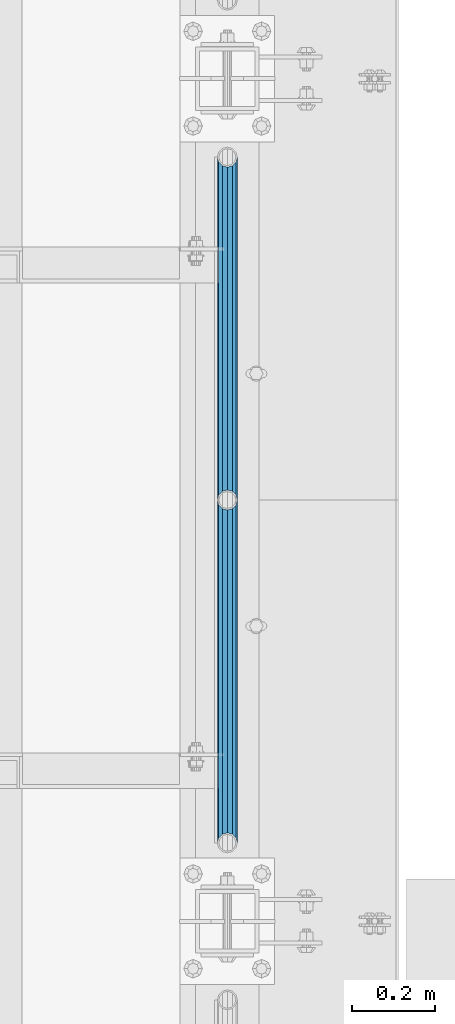
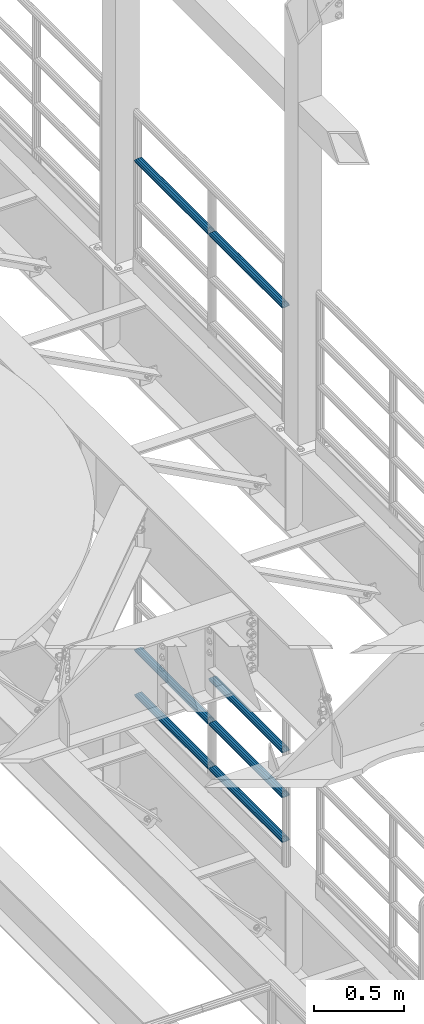
# One storey, part 1265 of 1876: 7 beams, 2 elements without a shape of their own.
"""IFC2X3 building model written with IfcOpenShell, lengths in millimetres."""

from ifc_helpers import new_model, si_unit, frame, origin_with_axes, place, context, subcontext, project, spatial, faceted_brep, material, type_object, element, aggregate, save


model = new_model("IFC2X3")

# Units and contexts
model_context = context("Model", 3, precision=1e-05, world=origin_with_axes())
body_context = subcontext(model_context, "Body", "Model", "MODEL_VIEW")
ifc_project = project(units=[si_unit("LENGTHUNIT", "METRE", prefix="MILLI"), si_unit("AREAUNIT", "SQUARE_METRE"), si_unit("VOLUMEUNIT", "CUBIC_METRE"), si_unit("MASSUNIT", "GRAM", prefix="KILO"), si_unit("TIMEUNIT", "SECOND"), si_unit("PLANEANGLEUNIT", "RADIAN"), si_unit("SOLIDANGLEUNIT", "STERADIAN"), si_unit("THERMODYNAMICTEMPERATUREUNIT", "DEGREE_CELSIUS"), si_unit("LUMINOUSINTENSITYUNIT", "LUMEN")], contexts=[model_context])

# Site, building, storey
site_placement = place(None, origin_with_axes())
site = spatial("IfcSite", under=ifc_project, at=site_placement, CompositionType="ELEMENT")
building_placement = place(site_placement, origin_with_axes())
building = spatial("IfcBuilding", under=site, at=building_placement, Name="Undefined", CompositionType="ELEMENT")
storey_placement = place(building_placement, origin_with_axes())
storey = spatial("IfcBuildingStorey", under=building, at=storey_placement, Name="Undefined", CompositionType="ELEMENT", Elevation=0.0)

# Assembly, beams
assembly_1_placement = place(storey_placement, origin_with_axes())
assembly_1 = element("IfcElementAssembly", 1, at=assembly_1_placement, inside=storey, Name="RAIL", AssemblyPlace="NOTDEFINED", PredefinedType="RIGID_FRAME")
ifc_material = material()
beam_type = type_object("IfcBeamType", Name="PIPE1-1/2SCH40", PredefinedType="NOTDEFINED")
beam_1_placement = place(assembly_1_placement, frame((7620.0, -2350.77, 8924.925), z_axis=(0.0, 0.0, -1.0), x_axis=(0.0, 1.0, 0.0)))
beam_1 = element("IfcBeam", 2, at=beam_1_placement, type_object=beam_type, material=ifc_material, Name="RAIL", ObjectType="PIPE1-1/2SCH40", context=body_context, shape_type="Brep", body=[
    faceted_brep([(0.0, 24.1299999999992, 0.0), (12.0650000000064, 20.8971929933177, -12.0649999999987), (12.0650000000064, 20.8971929933177, 12.0649999999987), (12.0650000000064, -20.8971929933177, 12.0649999999987), (12.0650000000064, -20.8971929933177, -12.0649999999987), (0.0, -24.1299999999992, 0.0), (20.8971929933249, -12.0650000000005, 20.8971929933177), (20.8971929933249, -12.0650000000005, 15.8661214311796), (15.2545715621445, -17.7076214311801, 10.2235000000001), (12.5151929933249, -20.4470000000001, 0.0), (15.2545715621445, -17.7076214311801, -10.2235000000001), (20.8971929933249, -12.0650000000005, -15.8661214311796), (20.8971929933249, -12.0650000000005, -20.8971929933177), (24.1300000000063, 0.0, -20.4470000000001), (24.1300000000063, 0.0, -24.130000000001), (21.3906214311868, -10.2235000000001, -17.7076214311819), (21.3906214311868, 10.2235000000001, -17.7076214311819), (20.8971929933249, 12.0650000000005, -15.8661214311796), (20.8971929933249, 12.0650000000005, -20.8971929933177), (15.2545715621445, 17.7076214311801, -10.2235000000001), (12.5151929933249, 20.4470000000001, 0.0), (15.2545715621445, 17.7076214311801, 10.2235000000001), (20.8971929933249, 12.0650000000005, 15.8661214311796), (20.8971929933249, 12.0650000000005, 20.8971929933177), (21.3906214311868, 10.2235000000001, 17.7076214311819), (24.1300000000064, 0.0, 20.4470000000001), (24.1300000000064, 0.0, 24.130000000001), (21.3906214311868, -10.2235000000001, 17.7076214311819), (826.77, 24.1300000000001, 0.0), (814.705, 20.8971929933186, -12.0649999999987), (805.872807006681, 12.0649999999996, -20.8971929933177), (826.77, -24.1300000000001, 0.0), (814.705, -20.8971929933186, -12.0649999999987), (814.705, -20.8971929933186, 12.0649999999987), (805.872807006681, -12.0649999999996, 20.8971929933177), (805.872807006681, -12.0649999999996, -20.8971929933177), (802.640000000001, 0.0, -24.130000000001), (805.379378568819, 10.2235000000001, -17.7076214311819), (802.640000000001, 0.0, -20.4470000000001), (805.872807006683, 12.0649999999996, -15.8661214311796), (805.872807006683, -12.0649999999996, -15.8661214311796), (805.379378568819, -10.2235000000001, -17.7076214311819), (811.515428437862, -17.7076214311801, -10.2235000000001), (814.254807006682, -20.4470000000001, 0.0), (811.515428437862, -17.7076214311801, 10.2235000000001), (805.872807006683, -12.0649999999996, 15.8661214311796), (805.379378568819, -10.2235000000001, 17.7076214311819), (802.640000000001, 0.0, 20.4470000000001), (802.640000000001, 0.0, 24.130000000001), (805.872807006681, 12.0649999999996, 20.8971929933177), (814.705, 20.8971929933186, 12.0649999999987), (805.872807006683, 12.0649999999996, 15.8661214311796), (811.515428437862, 17.7076214311801, 10.2235000000001), (814.254807006682, 20.4470000000001, 0.0), (811.515428437862, 17.7076214311801, -10.2235000000001), (805.379378568819, 10.2235000000001, 17.7076214311819)], [[[0, 1, 2]], [[3, 4, 5]], [[6, 7, 8, 9, 10, 11, 12, 4, 3]], [[13, 14, 12, 11, 15]], [[16, 17, 18, 14, 13]], [[2, 1, 18, 17, 19, 20, 21, 22, 23]], [[23, 22, 24, 25, 26]], [[26, 25, 27, 7, 6]], [[1, 0, 28, 29]], [[18, 1, 29, 30]], [[31, 32, 33]], [[6, 3, 33, 34]], [[3, 5, 31, 33]], [[5, 4, 32, 31]], [[4, 12, 35, 32]], [[12, 14, 36, 35]], [[14, 18, 30, 36]], [[37, 38, 36, 30, 39]], [[40, 35, 36, 38, 41]], [[33, 32, 35, 40, 42, 43, 44, 45, 34]], [[34, 45, 46, 47, 48]], [[26, 6, 34, 48]], [[2, 23, 49, 50]], [[23, 26, 48, 49]], [[0, 2, 50, 28]], [[28, 50, 29]], [[49, 51, 52, 53, 54, 39, 30, 29, 50]], [[48, 47, 55, 51, 49]], [[25, 24, 55, 47]], [[55, 24, 22, 21, 52, 51]], [[21, 20, 53, 52]], [[20, 19, 54, 53]], [[19, 17, 16, 37, 39, 54]], [[16, 13, 38, 37]], [[13, 15, 41, 38]], [[41, 15, 11, 10, 42, 40]], [[10, 9, 43, 42]], [[9, 8, 44, 43]], [[8, 7, 27, 46, 45, 44]], [[27, 25, 47, 46]]]),
])
beam_2_placement = place(assembly_1_placement, frame((7620.0, -1524.0, 8924.925), z_axis=(0.0, 0.0, -1.0), x_axis=(0.0, 1.0, 0.0)))
beam_2 = element("IfcBeam", 3, at=beam_2_placement, type_object=beam_type, material=ifc_material, Name="RAIL", ObjectType="PIPE1-1/2SCH40", context=body_context, shape_type="Brep", body=[
    faceted_brep([(0.0, 24.1299999999992, 0.0), (12.0650000000064, 20.8971929933177, -12.0649999999987), (12.0650000000064, 20.8971929933177, 12.0649999999987), (12.0650000000064, -20.8971929933177, 12.0649999999987), (12.0650000000064, -20.8971929933177, -12.0649999999987), (0.0, -24.1299999999992, 0.0), (20.8971929933249, -12.0650000000005, 20.8971929933177), (20.8971929933249, -12.0650000000005, 15.8661214311796), (15.2545715621445, -17.7076214311801, 10.2235000000001), (12.5151929933249, -20.4470000000001, 0.0), (15.2545715621445, -17.7076214311801, -10.2235000000001), (20.8971929933249, -12.0650000000005, -15.8661214311796), (20.8971929933249, -12.0650000000005, -20.8971929933177), (24.1300000000063, 0.0, -20.4470000000001), (24.1300000000063, 0.0, -24.130000000001), (21.3906214311868, -10.2235000000001, -17.7076214311819), (21.3906214311868, 10.2235000000001, -17.7076214311819), (20.8971929933249, 12.0650000000005, -15.8661214311796), (20.8971929933249, 12.0650000000005, -20.8971929933177), (15.2545715621445, 17.7076214311801, -10.2235000000001), (12.5151929933249, 20.4470000000001, 0.0), (15.2545715621445, 17.7076214311801, 10.2235000000001), (20.8971929933249, 12.0650000000005, 15.8661214311796), (20.8971929933249, 12.0650000000005, 20.8971929933177), (21.3906214311868, 10.2235000000001, 17.7076214311819), (24.1300000000064, 0.0, 20.4470000000001), (24.1300000000064, 0.0, 24.130000000001), (21.3906214311868, -10.2235000000001, 17.7076214311819), (826.77, 24.1300000000001, 0.0), (814.705, 20.8971929933186, -12.0649999999987), (805.872807006681, 12.0649999999996, -20.8971929933177), (826.77, -24.1300000000001, 0.0), (814.705, -20.8971929933186, -12.0649999999987), (814.705, -20.8971929933186, 12.0649999999987), (805.872807006681, -12.0649999999996, 20.8971929933177), (805.872807006681, -12.0649999999996, -20.8971929933177), (802.640000000001, 0.0, -24.130000000001), (805.379378568819, 10.2235000000001, -17.7076214311819), (802.640000000001, 0.0, -20.4470000000001), (805.872807006683, 12.0649999999996, -15.8661214311796), (805.872807006683, -12.0649999999996, -15.8661214311796), (805.379378568819, -10.2235000000001, -17.7076214311819), (811.515428437862, -17.7076214311801, -10.2235000000001), (814.254807006682, -20.4470000000001, 0.0), (811.515428437862, -17.7076214311801, 10.2235000000001), (805.872807006683, -12.0649999999996, 15.8661214311796), (805.379378568819, -10.2235000000001, 17.7076214311819), (802.640000000001, 0.0, 20.4470000000001), (802.640000000001, 0.0, 24.130000000001), (805.872807006681, 12.0649999999996, 20.8971929933177), (814.705, 20.8971929933186, 12.0649999999987), (805.872807006683, 12.0649999999996, 15.8661214311796), (811.515428437862, 17.7076214311801, 10.2235000000001), (814.254807006682, 20.4470000000001, 0.0), (811.515428437862, 17.7076214311801, -10.2235000000001), (805.379378568819, 10.2235000000001, 17.7076214311819)], [[[0, 1, 2]], [[3, 4, 5]], [[6, 7, 8, 9, 10, 11, 12, 4, 3]], [[13, 14, 12, 11, 15]], [[16, 17, 18, 14, 13]], [[2, 1, 18, 17, 19, 20, 21, 22, 23]], [[23, 22, 24, 25, 26]], [[26, 25, 27, 7, 6]], [[1, 0, 28, 29]], [[18, 1, 29, 30]], [[31, 32, 33]], [[6, 3, 33, 34]], [[3, 5, 31, 33]], [[5, 4, 32, 31]], [[4, 12, 35, 32]], [[12, 14, 36, 35]], [[14, 18, 30, 36]], [[37, 38, 36, 30, 39]], [[40, 35, 36, 38, 41]], [[33, 32, 35, 40, 42, 43, 44, 45, 34]], [[34, 45, 46, 47, 48]], [[26, 6, 34, 48]], [[2, 23, 49, 50]], [[23, 26, 48, 49]], [[0, 2, 50, 28]], [[28, 50, 29]], [[49, 51, 52, 53, 54, 39, 30, 29, 50]], [[48, 47, 55, 51, 49]], [[25, 24, 55, 47]], [[55, 24, 22, 21, 52, 51]], [[21, 20, 53, 52]], [[20, 19, 54, 53]], [[19, 17, 16, 37, 39, 54]], [[16, 13, 38, 37]], [[13, 15, 41, 38]], [[41, 15, 11, 10, 42, 40]], [[10, 9, 43, 42]], [[9, 8, 44, 43]], [[8, 7, 27, 46, 45, 44]], [[27, 25, 47, 46]]]),
])
aggregate(assembly_1, [beam_1, beam_2])

assembly_2_placement = place(storey_placement, origin_with_axes())
assembly_2 = element("IfcElementAssembly", 4, at=assembly_2_placement, inside=storey, Name="RAIL", AssemblyPlace="NOTDEFINED", PredefinedType="RIGID_FRAME")
beam_3_placement = place(assembly_2_placement, frame((7620.0, -1524.0, 5292.725), z_axis=(0.0, 0.0, 1.0), x_axis=(0.0, -1.0, 0.0)))
beam_3 = element("IfcBeam", 5, at=beam_3_placement, type_object=beam_type, material=ifc_material, Name="RAIL", ObjectType="PIPE1-1/2SCH40", context=body_context, shape_type="Brep", body=[
    faceted_brep([(805.872807006681, -12.0649999999996, 20.8971929933177), (805.872807006683, -12.0649999999996, 15.8661214311796), (805.379378568819, -10.2235000000001, 17.7076214311819), (802.640000000001, 0.0, 20.4470000000001), (802.640000000001, 0.0, 24.130000000001), (805.379378568819, 10.2235000000001, 17.7076214311819), (805.872807006683, 12.0649999999996, 15.8661214311796), (805.872807006681, 12.0649999999996, 20.8971929933177), (826.77, 24.1300000000001, 0.0), (814.705, 20.8971929933186, 12.0649999999987), (814.705, 20.8971929933186, -12.0649999999987), (811.515428437862, 17.7076214311801, 10.2235000000001), (814.254807006682, 20.4470000000001, 0.0), (811.515428437862, 17.7076214311801, -10.2235000000001), (805.872807006683, 12.0649999999996, -15.8661214311796), (805.872807006681, 12.0649999999996, -20.8971929933177), (805.379378568819, 10.2235000000001, -17.7076214311819), (802.640000000001, 0.0, -20.4470000000001), (802.640000000001, 0.0, -24.130000000001), (805.872807006683, -12.0649999999996, -15.8661214311796), (805.872807006681, -12.0649999999996, -20.8971929933177), (805.379378568819, -10.2235000000001, -17.7076214311819), (826.77, -24.1300000000001, 0.0), (814.705, -20.8971929933186, -12.0649999999987), (814.705, -20.8971929933186, 12.0649999999987), (811.515428437862, -17.7076214311801, -10.2235000000001), (814.254807006682, -20.4470000000001, 0.0), (811.515428437862, -17.7076214311801, 10.2235000000001), (12.0650000000064, -20.8971929933177, -12.0649999999987), (20.8971929933249, -12.0650000000005, -20.8971929933177), (0.0, 24.1299999999992, 0.0), (12.0650000000064, 20.8971929933177, -12.0649999999987), (12.0650000000064, 20.8971929933177, 12.0649999999987), (20.8971929933249, 12.0650000000005, 20.8971929933177), (24.1300000000064, 0.0, 24.130000000001), (20.8971929933249, 12.0650000000005, -20.8971929933177), (24.1300000000063, 0.0, -24.130000000001), (24.1300000000063, 0.0, -20.4470000000001), (20.8971929933249, -12.0650000000005, -15.8661214311796), (21.3906214311868, -10.2235000000001, -17.7076214311819), (21.3906214311868, 10.2235000000001, -17.7076214311819), (20.8971929933249, 12.0650000000005, -15.8661214311796), (15.2545715621445, 17.7076214311801, -10.2235000000001), (12.5151929933249, 20.4470000000001, 0.0), (15.2545715621445, 17.7076214311801, 10.2235000000001), (20.8971929933249, 12.0650000000005, 15.8661214311796), (21.3906214311868, 10.2235000000001, 17.7076214311819), (24.1300000000064, 0.0, 20.4470000000001), (21.3906214311868, -10.2235000000001, 17.7076214311819), (20.8971929933249, -12.0650000000005, 15.8661214311796), (20.8971929933249, -12.0650000000005, 20.8971929933177), (12.0650000000064, -20.8971929933177, 12.0649999999987), (0.0, -24.1299999999992, 0.0), (15.2545715621445, -17.7076214311801, 10.2235000000001), (12.5151929933249, -20.4470000000001, 0.0), (15.2545715621445, -17.7076214311801, -10.2235000000001)], [[[0, 1, 2, 3, 4]], [[4, 3, 5, 6, 7]], [[8, 9, 10]], [[7, 6, 11, 12, 13, 14, 15, 10, 9]], [[16, 17, 18, 15, 14]], [[19, 20, 18, 17, 21]], [[22, 23, 24]], [[24, 23, 20, 19, 25, 26, 27, 1, 0]], [[28, 29, 20, 23]], [[30, 31, 32]], [[33, 34, 4, 7]], [[32, 33, 7, 9]], [[30, 32, 9, 8]], [[31, 30, 8, 10]], [[35, 31, 10, 15]], [[36, 35, 15, 18]], [[29, 36, 18, 20]], [[37, 36, 29, 38, 39]], [[40, 41, 35, 36, 37]], [[32, 31, 35, 41, 42, 43, 44, 45, 33]], [[33, 45, 46, 47, 34]], [[34, 47, 48, 49, 50]], [[34, 50, 0, 4]], [[50, 51, 24, 0]], [[51, 52, 22, 24]], [[52, 28, 23, 22]], [[51, 28, 52]], [[50, 49, 53, 54, 55, 38, 29, 28, 51]], [[55, 54, 26, 25]], [[21, 39, 38, 55, 25, 19]], [[37, 39, 21, 17]], [[40, 37, 17, 16]], [[42, 41, 40, 16, 14, 13]], [[43, 42, 13, 12]], [[44, 43, 12, 11]], [[5, 46, 45, 44, 11, 6]], [[47, 46, 5, 3]], [[48, 47, 3, 2]], [[53, 49, 48, 2, 1, 27]], [[54, 53, 27, 26]]]),
])
beam_4_placement = place(assembly_2_placement, frame((7620.0, -697.230000000005, 5292.725), z_axis=(0.0, 0.0, 1.0), x_axis=(0.0, -1.0, 0.0)))
beam_4 = element("IfcBeam", 6, at=beam_4_placement, type_object=beam_type, material=ifc_material, Name="RAIL", ObjectType="PIPE1-1/2SCH40", context=body_context, shape_type="Brep", body=[
    faceted_brep([(805.872807006681, -12.0649999999996, 20.8971929933177), (805.872807006683, -12.0649999999996, 15.8661214311796), (805.379378568819, -10.2235000000001, 17.7076214311819), (802.640000000001, 0.0, 20.4470000000001), (802.640000000001, 0.0, 24.130000000001), (805.379378568819, 10.2235000000001, 17.7076214311819), (805.872807006683, 12.0649999999996, 15.8661214311796), (805.872807006681, 12.0649999999996, 20.8971929933177), (826.77, 24.1300000000001, 0.0), (814.705, 20.8971929933186, 12.0649999999987), (814.705, 20.8971929933186, -12.0649999999987), (811.515428437862, 17.7076214311801, 10.2235000000001), (814.254807006682, 20.4470000000001, 0.0), (811.515428437862, 17.7076214311801, -10.2235000000001), (805.872807006683, 12.0649999999996, -15.8661214311796), (805.872807006681, 12.0649999999996, -20.8971929933177), (805.379378568819, 10.2235000000001, -17.7076214311819), (802.640000000001, 0.0, -20.4470000000001), (802.640000000001, 0.0, -24.130000000001), (805.872807006683, -12.0649999999996, -15.8661214311796), (805.872807006681, -12.0649999999996, -20.8971929933177), (805.379378568819, -10.2235000000001, -17.7076214311819), (826.77, -24.1300000000001, 0.0), (814.705, -20.8971929933186, -12.0649999999987), (814.705, -20.8971929933186, 12.0649999999987), (811.515428437862, -17.7076214311801, -10.2235000000001), (814.254807006682, -20.4470000000001, 0.0), (811.515428437862, -17.7076214311801, 10.2235000000001), (12.0650000000064, -20.8971929933177, -12.0649999999987), (20.8971929933249, -12.0650000000005, -20.8971929933177), (0.0, 24.1299999999992, 0.0), (12.0650000000064, 20.8971929933177, -12.0649999999987), (12.0650000000064, 20.8971929933177, 12.0649999999987), (20.8971929933249, 12.0650000000005, 20.8971929933177), (24.1300000000064, 0.0, 24.130000000001), (20.8971929933249, 12.0650000000005, -20.8971929933177), (24.1300000000063, 0.0, -24.130000000001), (24.1300000000063, 0.0, -20.4470000000001), (20.8971929933249, -12.0650000000005, -15.8661214311796), (21.3906214311868, -10.2235000000001, -17.7076214311819), (21.3906214311868, 10.2235000000001, -17.7076214311819), (20.8971929933249, 12.0650000000005, -15.8661214311796), (15.2545715621445, 17.7076214311801, -10.2235000000001), (12.5151929933249, 20.4470000000001, 0.0), (15.2545715621445, 17.7076214311801, 10.2235000000001), (20.8971929933249, 12.0650000000005, 15.8661214311796), (21.3906214311868, 10.2235000000001, 17.7076214311819), (24.1300000000064, 0.0, 20.4470000000001), (21.3906214311868, -10.2235000000001, 17.7076214311819), (20.8971929933249, -12.0650000000005, 15.8661214311796), (20.8971929933249, -12.0650000000005, 20.8971929933177), (12.0650000000064, -20.8971929933177, 12.0649999999987), (0.0, -24.1299999999992, 0.0), (15.2545715621445, -17.7076214311801, 10.2235000000001), (12.5151929933249, -20.4470000000001, 0.0), (15.2545715621445, -17.7076214311801, -10.2235000000001)], [[[0, 1, 2, 3, 4]], [[4, 3, 5, 6, 7]], [[8, 9, 10]], [[7, 6, 11, 12, 13, 14, 15, 10, 9]], [[16, 17, 18, 15, 14]], [[19, 20, 18, 17, 21]], [[22, 23, 24]], [[24, 23, 20, 19, 25, 26, 27, 1, 0]], [[28, 29, 20, 23]], [[30, 31, 32]], [[33, 34, 4, 7]], [[32, 33, 7, 9]], [[30, 32, 9, 8]], [[31, 30, 8, 10]], [[35, 31, 10, 15]], [[36, 35, 15, 18]], [[29, 36, 18, 20]], [[37, 36, 29, 38, 39]], [[40, 41, 35, 36, 37]], [[32, 31, 35, 41, 42, 43, 44, 45, 33]], [[33, 45, 46, 47, 34]], [[34, 47, 48, 49, 50]], [[34, 50, 0, 4]], [[50, 51, 24, 0]], [[51, 52, 22, 24]], [[52, 28, 23, 22]], [[51, 28, 52]], [[50, 49, 53, 54, 55, 38, 29, 28, 51]], [[55, 54, 26, 25]], [[21, 39, 38, 55, 25, 19]], [[37, 39, 21, 17]], [[40, 37, 17, 16]], [[42, 41, 40, 16, 14, 13]], [[43, 42, 13, 12]], [[44, 43, 12, 11]], [[5, 46, 45, 44, 11, 6]], [[47, 46, 5, 3]], [[48, 47, 3, 2]], [[53, 49, 48, 2, 1, 27]], [[54, 53, 27, 26]]]),
])
beam_5_placement = place(assembly_2_placement, frame((7620.0, -2350.77, 5597.525), z_axis=(0.0, 0.0, -1.0), x_axis=(0.0, 1.0, 0.0)))
beam_5 = element("IfcBeam", 7, at=beam_5_placement, type_object=beam_type, material=ifc_material, Name="RAIL", ObjectType="PIPE1-1/2SCH40", context=body_context, shape_type="Brep", body=[
    faceted_brep([(0.0, 24.1299999999992, 0.0), (12.0650000000064, 20.8971929933177, -12.0649999999987), (12.0650000000064, 20.8971929933177, 12.0649999999987), (12.0650000000064, -20.8971929933177, 12.0649999999987), (12.0650000000064, -20.8971929933177, -12.0649999999987), (0.0, -24.1299999999992, 0.0), (20.8971929933249, -12.0650000000005, 20.8971929933177), (20.8971929933249, -12.0650000000005, 15.8661214311796), (15.2545715621445, -17.7076214311801, 10.2235000000001), (12.5151929933249, -20.4470000000001, 0.0), (15.2545715621445, -17.7076214311801, -10.2235000000001), (20.8971929933249, -12.0650000000005, -15.8661214311796), (20.8971929933249, -12.0650000000005, -20.8971929933177), (24.1300000000063, 0.0, -20.4470000000001), (24.1300000000063, 0.0, -24.130000000001), (21.3906214311868, -10.2235000000001, -17.7076214311819), (21.3906214311868, 10.2235000000001, -17.7076214311819), (20.8971929933249, 12.0650000000005, -15.8661214311796), (20.8971929933249, 12.0650000000005, -20.8971929933177), (15.2545715621445, 17.7076214311801, -10.2235000000001), (12.5151929933249, 20.4470000000001, 0.0), (15.2545715621445, 17.7076214311801, 10.2235000000001), (20.8971929933249, 12.0650000000005, 15.8661214311796), (20.8971929933249, 12.0650000000005, 20.8971929933177), (21.3906214311868, 10.2235000000001, 17.7076214311819), (24.1300000000064, 0.0, 20.4470000000001), (24.1300000000064, 0.0, 24.130000000001), (21.3906214311868, -10.2235000000001, 17.7076214311819), (826.77, 24.1300000000001, 0.0), (814.705, 20.8971929933186, -12.0649999999987), (805.872807006681, 12.0649999999996, -20.8971929933177), (826.77, -24.1300000000001, 0.0), (814.705, -20.8971929933186, -12.0649999999987), (814.705, -20.8971929933186, 12.0649999999987), (805.872807006681, -12.0649999999996, 20.8971929933177), (805.872807006681, -12.0649999999996, -20.8971929933177), (802.640000000001, 0.0, -24.130000000001), (805.379378568819, 10.2235000000001, -17.7076214311819), (802.640000000001, 0.0, -20.4470000000001), (805.872807006683, 12.0649999999996, -15.8661214311796), (805.872807006683, -12.0649999999996, -15.8661214311796), (805.379378568819, -10.2235000000001, -17.7076214311819), (811.515428437862, -17.7076214311801, -10.2235000000001), (814.254807006682, -20.4470000000001, 0.0), (811.515428437862, -17.7076214311801, 10.2235000000001), (805.872807006683, -12.0649999999996, 15.8661214311796), (805.379378568819, -10.2235000000001, 17.7076214311819), (802.640000000001, 0.0, 20.4470000000001), (802.640000000001, 0.0, 24.130000000001), (805.872807006681, 12.0649999999996, 20.8971929933177), (814.705, 20.8971929933186, 12.0649999999987), (805.872807006683, 12.0649999999996, 15.8661214311796), (811.515428437862, 17.7076214311801, 10.2235000000001), (814.254807006682, 20.4470000000001, 0.0), (811.515428437862, 17.7076214311801, -10.2235000000001), (805.379378568819, 10.2235000000001, 17.7076214311819)], [[[0, 1, 2]], [[3, 4, 5]], [[6, 7, 8, 9, 10, 11, 12, 4, 3]], [[13, 14, 12, 11, 15]], [[16, 17, 18, 14, 13]], [[2, 1, 18, 17, 19, 20, 21, 22, 23]], [[23, 22, 24, 25, 26]], [[26, 25, 27, 7, 6]], [[1, 0, 28, 29]], [[18, 1, 29, 30]], [[31, 32, 33]], [[6, 3, 33, 34]], [[3, 5, 31, 33]], [[5, 4, 32, 31]], [[4, 12, 35, 32]], [[12, 14, 36, 35]], [[14, 18, 30, 36]], [[37, 38, 36, 30, 39]], [[40, 35, 36, 38, 41]], [[33, 32, 35, 40, 42, 43, 44, 45, 34]], [[34, 45, 46, 47, 48]], [[26, 6, 34, 48]], [[2, 23, 49, 50]], [[23, 26, 48, 49]], [[0, 2, 50, 28]], [[28, 50, 29]], [[49, 51, 52, 53, 54, 39, 30, 29, 50]], [[48, 47, 55, 51, 49]], [[25, 24, 55, 47]], [[55, 24, 22, 21, 52, 51]], [[21, 20, 53, 52]], [[20, 19, 54, 53]], [[19, 17, 16, 37, 39, 54]], [[16, 13, 38, 37]], [[13, 15, 41, 38]], [[41, 15, 11, 10, 42, 40]], [[10, 9, 43, 42]], [[9, 8, 44, 43]], [[8, 7, 27, 46, 45, 44]], [[27, 25, 47, 46]]]),
])
beam_6_placement = place(assembly_2_placement, frame((7620.0, -1524.0, 5597.525), z_axis=(0.0, 0.0, -1.0), x_axis=(0.0, 1.0, 0.0)))
beam_6 = element("IfcBeam", 8, at=beam_6_placement, type_object=beam_type, material=ifc_material, Name="RAIL", ObjectType="PIPE1-1/2SCH40", context=body_context, shape_type="Brep", body=[
    faceted_brep([(0.0, 24.1299999999992, 0.0), (12.0650000000064, 20.8971929933177, -12.0649999999987), (12.0650000000064, 20.8971929933177, 12.0649999999987), (12.0650000000064, -20.8971929933177, 12.0649999999987), (12.0650000000064, -20.8971929933177, -12.0649999999987), (0.0, -24.1299999999992, 0.0), (20.8971929933249, -12.0650000000005, 20.8971929933177), (20.8971929933249, -12.0650000000005, 15.8661214311796), (15.2545715621445, -17.7076214311801, 10.2235000000001), (12.5151929933249, -20.4470000000001, 0.0), (15.2545715621445, -17.7076214311801, -10.2235000000001), (20.8971929933249, -12.0650000000005, -15.8661214311796), (20.8971929933249, -12.0650000000005, -20.8971929933177), (24.1300000000063, 0.0, -20.4470000000001), (24.1300000000063, 0.0, -24.130000000001), (21.3906214311868, -10.2235000000001, -17.7076214311819), (21.3906214311868, 10.2235000000001, -17.7076214311819), (20.8971929933249, 12.0650000000005, -15.8661214311796), (20.8971929933249, 12.0650000000005, -20.8971929933177), (15.2545715621445, 17.7076214311801, -10.2235000000001), (12.5151929933249, 20.4470000000001, 0.0), (15.2545715621445, 17.7076214311801, 10.2235000000001), (20.8971929933249, 12.0650000000005, 15.8661214311796), (20.8971929933249, 12.0650000000005, 20.8971929933177), (21.3906214311868, 10.2235000000001, 17.7076214311819), (24.1300000000064, 0.0, 20.4470000000001), (24.1300000000064, 0.0, 24.130000000001), (21.3906214311868, -10.2235000000001, 17.7076214311819), (826.77, 24.1300000000001, 0.0), (814.705, 20.8971929933186, -12.0649999999987), (805.872807006681, 12.0649999999996, -20.8971929933177), (826.77, -24.1300000000001, 0.0), (814.705, -20.8971929933186, -12.0649999999987), (814.705, -20.8971929933186, 12.0649999999987), (805.872807006681, -12.0649999999996, 20.8971929933177), (805.872807006681, -12.0649999999996, -20.8971929933177), (802.640000000001, 0.0, -24.130000000001), (805.379378568819, 10.2235000000001, -17.7076214311819), (802.640000000001, 0.0, -20.4470000000001), (805.872807006683, 12.0649999999996, -15.8661214311796), (805.872807006683, -12.0649999999996, -15.8661214311796), (805.379378568819, -10.2235000000001, -17.7076214311819), (811.515428437862, -17.7076214311801, -10.2235000000001), (814.254807006682, -20.4470000000001, 0.0), (811.515428437862, -17.7076214311801, 10.2235000000001), (805.872807006683, -12.0649999999996, 15.8661214311796), (805.379378568819, -10.2235000000001, 17.7076214311819), (802.640000000001, 0.0, 20.4470000000001), (802.640000000001, 0.0, 24.130000000001), (805.872807006681, 12.0649999999996, 20.8971929933177), (814.705, 20.8971929933186, 12.0649999999987), (805.872807006683, 12.0649999999996, 15.8661214311796), (811.515428437862, 17.7076214311801, 10.2235000000001), (814.254807006682, 20.4470000000001, 0.0), (811.515428437862, 17.7076214311801, -10.2235000000001), (805.379378568819, 10.2235000000001, 17.7076214311819)], [[[0, 1, 2]], [[3, 4, 5]], [[6, 7, 8, 9, 10, 11, 12, 4, 3]], [[13, 14, 12, 11, 15]], [[16, 17, 18, 14, 13]], [[2, 1, 18, 17, 19, 20, 21, 22, 23]], [[23, 22, 24, 25, 26]], [[26, 25, 27, 7, 6]], [[1, 0, 28, 29]], [[18, 1, 29, 30]], [[31, 32, 33]], [[6, 3, 33, 34]], [[3, 5, 31, 33]], [[5, 4, 32, 31]], [[4, 12, 35, 32]], [[12, 14, 36, 35]], [[14, 18, 30, 36]], [[37, 38, 36, 30, 39]], [[40, 35, 36, 38, 41]], [[33, 32, 35, 40, 42, 43, 44, 45, 34]], [[34, 45, 46, 47, 48]], [[26, 6, 34, 48]], [[2, 23, 49, 50]], [[23, 26, 48, 49]], [[0, 2, 50, 28]], [[28, 50, 29]], [[49, 51, 52, 53, 54, 39, 30, 29, 50]], [[48, 47, 55, 51, 49]], [[25, 24, 55, 47]], [[55, 24, 22, 21, 52, 51]], [[21, 20, 53, 52]], [[20, 19, 54, 53]], [[19, 17, 16, 37, 39, 54]], [[16, 13, 38, 37]], [[13, 15, 41, 38]], [[41, 15, 11, 10, 42, 40]], [[10, 9, 43, 42]], [[9, 8, 44, 43]], [[8, 7, 27, 46, 45, 44]], [[27, 25, 47, 46]]]),
])
beam_7_placement = place(assembly_2_placement, frame((7620.0, -2350.77, 5902.325), z_axis=(0.0, 0.0, -1.0), x_axis=(0.0, 1.0, 0.0)))
beam_7 = element("IfcBeam", 9, at=beam_7_placement, type_object=beam_type, material=ifc_material, Name="RAIL", ObjectType="PIPE1-1/2SCH40", context=body_context, shape_type="Brep", body=[
    faceted_brep([(0.0, 24.1299999999992, 0.0), (12.0650000000064, 20.8971929933177, -12.0649999999987), (12.0650000000064, 20.8971929933177, 12.0649999999987), (12.0650000000064, -20.8971929933177, 12.0649999999987), (12.0650000000064, -20.8971929933177, -12.0649999999987), (0.0, -24.1299999999992, 0.0), (20.8971929933249, -12.0650000000005, 20.8971929933177), (20.8971929933249, -12.0650000000005, 15.8661214311796), (15.2545715621445, -17.7076214311801, 10.2235000000001), (12.5151929933249, -20.4470000000001, 0.0), (15.2545715621445, -17.7076214311801, -10.2235000000001), (20.8971929933249, -12.0650000000005, -15.8661214311796), (20.8971929933249, -12.0650000000005, -20.8971929933177), (24.1300000000063, 0.0, -20.4470000000001), (24.1300000000063, 0.0, -24.130000000001), (21.3906214311868, -10.2235000000001, -17.7076214311819), (21.3906214311868, 10.2235000000001, -17.7076214311819), (20.8971929933249, 12.0650000000005, -15.8661214311796), (20.8971929933249, 12.0650000000005, -20.8971929933177), (15.2545715621445, 17.7076214311801, -10.2235000000001), (12.5151929933249, 20.4470000000001, 0.0), (15.2545715621445, 17.7076214311801, 10.2235000000001), (20.8971929933249, 12.0650000000005, 15.8661214311796), (20.8971929933249, 12.0650000000005, 20.8971929933177), (21.3906214311868, 10.2235000000001, 17.7076214311819), (24.1300000000064, 0.0, 20.4470000000001), (24.1300000000064, 0.0, 24.130000000001), (21.3906214311868, -10.2235000000001, 17.7076214311819), (826.77, 24.1300000000001, 0.0), (814.705, 20.8971929933186, -12.0649999999987), (805.872807006681, 12.0649999999996, -20.8971929933177), (826.77, -24.1300000000001, 0.0), (814.705, -20.8971929933186, -12.0649999999987), (814.705, -20.8971929933186, 12.0649999999987), (805.872807006681, -12.0649999999996, 20.8971929933177), (805.872807006681, -12.0649999999996, -20.8971929933177), (802.640000000001, 0.0, -24.130000000001), (805.379378568819, 10.2235000000001, -17.7076214311819), (802.640000000001, 0.0, -20.4470000000001), (805.872807006683, 12.0649999999996, -15.8661214311796), (805.872807006683, -12.0649999999996, -15.8661214311796), (805.379378568819, -10.2235000000001, -17.7076214311819), (811.515428437862, -17.7076214311801, -10.2235000000001), (814.254807006682, -20.4470000000001, 0.0), (811.515428437862, -17.7076214311801, 10.2235000000001), (805.872807006683, -12.0649999999996, 15.8661214311796), (805.379378568819, -10.2235000000001, 17.7076214311819), (802.640000000001, 0.0, 20.4470000000001), (802.640000000001, 0.0, 24.130000000001), (805.872807006681, 12.0649999999996, 20.8971929933177), (814.705, 20.8971929933186, 12.0649999999987), (805.872807006683, 12.0649999999996, 15.8661214311796), (811.515428437862, 17.7076214311801, 10.2235000000001), (814.254807006682, 20.4470000000001, 0.0), (811.515428437862, 17.7076214311801, -10.2235000000001), (805.379378568819, 10.2235000000001, 17.7076214311819)], [[[0, 1, 2]], [[3, 4, 5]], [[6, 7, 8, 9, 10, 11, 12, 4, 3]], [[13, 14, 12, 11, 15]], [[16, 17, 18, 14, 13]], [[2, 1, 18, 17, 19, 20, 21, 22, 23]], [[23, 22, 24, 25, 26]], [[26, 25, 27, 7, 6]], [[1, 0, 28, 29]], [[18, 1, 29, 30]], [[31, 32, 33]], [[6, 3, 33, 34]], [[3, 5, 31, 33]], [[5, 4, 32, 31]], [[4, 12, 35, 32]], [[12, 14, 36, 35]], [[14, 18, 30, 36]], [[37, 38, 36, 30, 39]], [[40, 35, 36, 38, 41]], [[33, 32, 35, 40, 42, 43, 44, 45, 34]], [[34, 45, 46, 47, 48]], [[26, 6, 34, 48]], [[2, 23, 49, 50]], [[23, 26, 48, 49]], [[0, 2, 50, 28]], [[28, 50, 29]], [[49, 51, 52, 53, 54, 39, 30, 29, 50]], [[48, 47, 55, 51, 49]], [[25, 24, 55, 47]], [[55, 24, 22, 21, 52, 51]], [[21, 20, 53, 52]], [[20, 19, 54, 53]], [[19, 17, 16, 37, 39, 54]], [[16, 13, 38, 37]], [[13, 15, 41, 38]], [[41, 15, 11, 10, 42, 40]], [[10, 9, 43, 42]], [[9, 8, 44, 43]], [[8, 7, 27, 46, 45, 44]], [[27, 25, 47, 46]]]),
])
aggregate(assembly_2, [beam_3, beam_4, beam_5, beam_6, beam_7])

save(model, "model.ifc")
